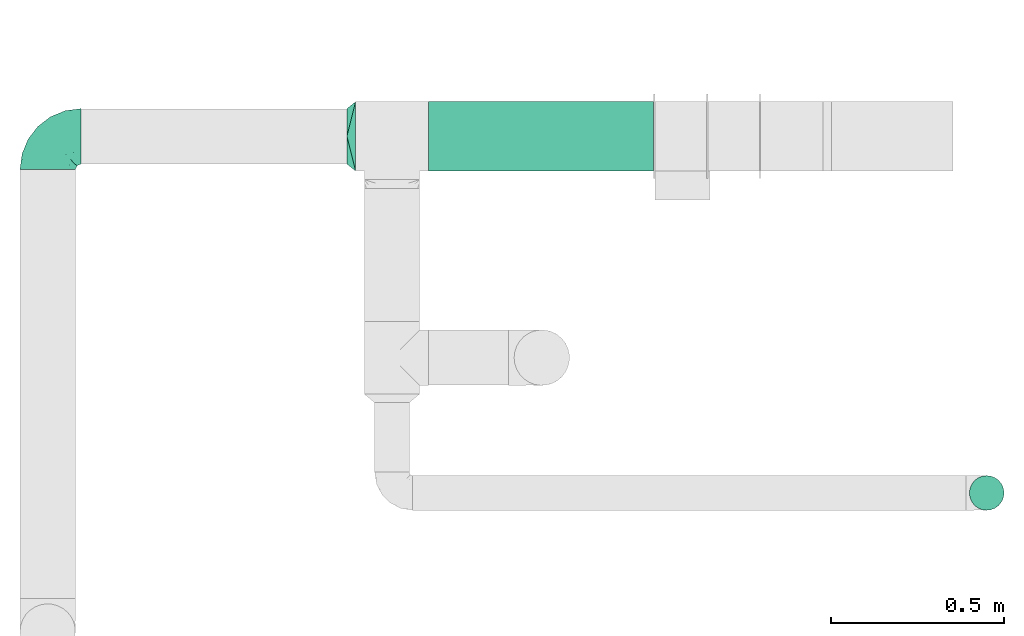
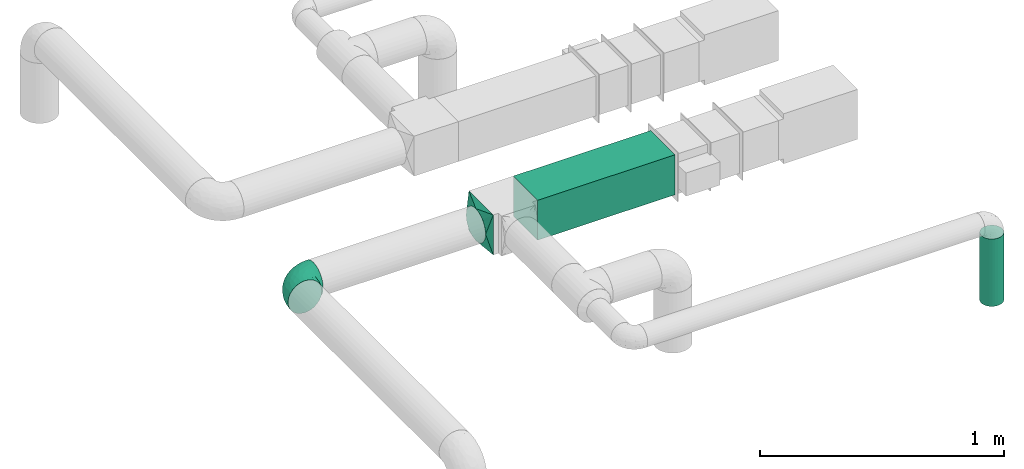
# One storey, part 5 of 12: 2 flow fittings, 2 flow segments.
"""IFC2X3 building model written with IfcOpenShell, lengths in millimetres."""

from ifc_helpers import new_model, entity, si_unit, converted_unit, derived_unit, direction, frame, frame_2d, origin, origin_2d_with_axis, place, context, subcontext, project, spatial, rectangle, circle, extrude, faceted_brep, source, transform, mapped, material, type_object, type_shapes, element, save


model = new_model("IFC2X3")

# Units and contexts
model_context = context("Model", 3, precision=0.01, world=origin(), true_north=direction((6.12303176911189e-17, 1.0)))
body_context = subcontext(model_context, "Body", "Model", "MODEL_VIEW")
ifc_project = project(units=[si_unit("LENGTHUNIT", "METRE", prefix="MILLI"), si_unit("AREAUNIT", "SQUARE_METRE"), si_unit("VOLUMEUNIT", "CUBIC_METRE"), converted_unit("PLANEANGLEUNIT", "DEGREE", entity("IfcRatioMeasure", 0.0174532925199433), si_unit("PLANEANGLEUNIT", "RADIAN"), dimensions=[0, 0, 0, 0, 0, 0, 0]), si_unit("MASSUNIT", "GRAM", prefix="KILO"), derived_unit("MASSDENSITYUNIT", [(si_unit("MASSUNIT", "GRAM", prefix="KILO"), 1), (si_unit("LENGTHUNIT", "METRE"), -3)]), si_unit("TIMEUNIT", "SECOND"), si_unit("FREQUENCYUNIT", "HERTZ"), si_unit("THERMODYNAMICTEMPERATUREUNIT", "DEGREE_CELSIUS"), derived_unit("THERMALTRANSMITTANCEUNIT", [(si_unit("MASSUNIT", "GRAM", prefix="KILO"), 1), (si_unit("THERMODYNAMICTEMPERATUREUNIT", "KELVIN"), -1), (si_unit("TIMEUNIT", "SECOND"), -3)]), derived_unit("VOLUMETRICFLOWRATEUNIT", [(si_unit("LENGTHUNIT", "METRE"), 3), (si_unit("TIMEUNIT", "SECOND"), -1)]), si_unit("ELECTRICCURRENTUNIT", "AMPERE"), si_unit("ELECTRICVOLTAGEUNIT", "VOLT"), si_unit("POWERUNIT", "WATT"), si_unit("FORCEUNIT", "NEWTON", prefix="KILO"), si_unit("ILLUMINANCEUNIT", "LUX"), si_unit("LUMINOUSFLUXUNIT", "LUMEN"), si_unit("LUMINOUSINTENSITYUNIT", "CANDELA"), derived_unit("USERDEFINED", [(si_unit("MASSUNIT", "GRAM", prefix="KILO"), -1), (si_unit("LENGTHUNIT", "METRE"), -2), (si_unit("TIMEUNIT", "SECOND"), 3), (si_unit("LUMINOUSFLUXUNIT", "LUMEN"), 1)]), derived_unit("LINEARVELOCITYUNIT", [(si_unit("LENGTHUNIT", "METRE"), 1), (si_unit("TIMEUNIT", "SECOND"), -1)]), si_unit("PRESSUREUNIT", "PASCAL"), derived_unit("USERDEFINED", [(si_unit("LENGTHUNIT", "METRE"), -2), (si_unit("MASSUNIT", "GRAM", prefix="KILO"), 1), (si_unit("TIMEUNIT", "SECOND"), -2)])], contexts=[model_context])

# Site, building, storey
site_placement = place(None, origin())
site = spatial("IfcSite", under=ifc_project, at=site_placement, CompositionType="ELEMENT")
building_placement = place(site_placement, origin())
building = spatial("IfcBuilding", under=site, at=building_placement, CompositionType="ELEMENT")
storey_placement = place(building_placement, frame((0.0, 0.0, 8000.0)))
storey = spatial("IfcBuildingStorey", under=building, at=storey_placement, Name="02 Level", CompositionType="ELEMENT", Elevation=8000.0)

# Flow segments
duct_segment_type_1 = type_object("IfcDuctSegmentType", Name="Round Duct:Air", PredefinedType="NOTDEFINED")
flow_segment_1_placement = place(storey_placement, frame((24851.8947986159, -70237.5308847274, 2603.07847999992)))
element("IfcFlowSegment", 1, at=flow_segment_1_placement, inside=storey, type_object=duct_segment_type_1, Name="Round Duct:Air", ObjectType="Round Duct:Air", context=body_context, shape_type="SweptSolid", body=[
    extrude(circle(Radius=50.0, at=origin_2d_with_axis()), frame((51.5952722359175, 51.5952722364156, 0.0), z_axis=(0.0, 0.0, 1.0), x_axis=(0.0, 1.0, 0.0)), (0.0, 0.0, 1.0), 336.921519999948),
])
duct_segment_type_2 = type_object("IfcDuctSegmentType", Name="Rectangular Duct:Air", PredefinedType="NOTDEFINED")
flow_segment_2_placement = place(storey_placement, frame((23290.9900708518, -69256.0352293172, 2900.0)))
element("IfcFlowSegment", 2, at=flow_segment_2_placement, inside=storey, type_object=duct_segment_type_2, Name="Rectangular Duct:Air", ObjectType="Rectangular Duct:Air", context=body_context, shape_type="SweptSolid", body=[
    extrude(rectangle(XDim=650.000000000004, YDim=199.999999999998, at=frame_2d((-2.1600499167107e-12, -4.33431068813661e-12), x_axis=(1.0, 0.0))), frame((325.0, 100.0, 0.0), z_axis=(0.0, 0.0, 1.0), x_axis=(-1.0, 0.0, 0.0)), (0.0, 0.0, 1.0), 200.000000000002),
])

# Flow fittings
duct_fitting_type_1 = type_object("IfcDuctFittingType", Name="Air_Elbow short_Circ", PredefinedType="NOTDEFINED")
shared_shape_1 = source(origin(), body_context, "Body", "Brep", [
    faceted_brep([(-96.0, 40.0, -69.2820323027551), (-96.0, 20.7055236082018, -77.2740661031254), (-96.0, 0.0, -80.0), (-96.0, -20.7055236082015, -77.2740661031255), (-96.0, -40.0, -69.2820323027552), (-96.0, -56.5685424949237, -56.5685424949239), (-96.0, -69.282032302755, -40.0), (-96.0, -77.2740661031254, -20.7055236082019), (-96.0, -80.0, 0.0), (-96.0, -77.2740661031256, 20.7055236082014), (-96.0, -69.2820323027553, 40.0), (-96.0, -56.568542494924, 56.5685424949236), (-96.0, -40.0, 69.2820323027549), (-96.0, -20.705523608202, 77.2740661031254), (-96.0, 0.0, 80.0), (-96.0, 20.7055236082013, 77.2740661031256), (-96.0, 30.3527618041005, 73.2780492029404), (-96.0, 40.0, 69.2820323027553), (-96.0, 56.5685424949235, 56.5685424949241), (-96.0, 69.2820323027549, 40.0), (-96.0, 77.2740661031253, 20.7055236082021), (-96.0, 80.0, 0.0), (-96.0, 77.2740661031255, -20.7055236082016), (-96.0, 69.2820323027551, -40.0), (-96.0, 56.5685424949239, -56.5685424949238), (0.0, 96.0, -80.0), (-20.7055236082008, 96.0, -77.2740661031254), (-30.3527618041, 96.0, -73.2780492029402), (-40.0, 96.0, -69.2820323027551), (-56.5685424949229, 96.0, -56.5685424949238), (-69.2820323027542, 96.0, -40.0), (-77.2740661031245, 96.0, -20.7055236082016), (-80.0, 96.0, 0.0), (-77.2740661031244, 96.0, 20.7055236082021), (-69.2820323027539, 96.0, 40.0), (-56.5685424949226, 96.0, 56.5685424949241), (-40.0, 96.0, 69.2820323027553), (-20.7055236082004, 96.0, 77.2740661031256), (0.0, 96.0, 80.0), (20.7055236082029, 96.0, 77.2740661031254), (40.0, 96.0, 69.2820323027549), (56.5685424949249, 96.0, 56.5685424949236), (69.2820323027562, 96.0, 40.0), (77.2740661031265, 96.0, 20.7055236082014), (80.0, 96.0, 0.0), (77.2740661031264, 96.0, -20.7055236082019), (69.2820323027559, 96.0, -40.0), (56.5685424949246, 96.0, -56.5685424949239), (40.0, 96.0, -69.2820323027552), (20.7055236082025, 96.0, -77.2740661031255), (-69.6571465232348, 6.28172173912476, 79.9611058756859), (-55.1380888291464, -64.4450584799279, 39.5029426177976), (-78.4902527850466, -65.2482264041437, 44.9229732355936), (-66.7862289407348, -74.1387210661139, 22.9795507758541), (-79.9123689128389, 22.4151301859584, 77.2816866630488), (-75.1250134759213, 46.3506195730757, 68.0011973810265), (-46.2820694578435, -43.7397705581167, 60.5188244193914), (-62.9760666105318, -34.5362195419601, 70.0448030595901), (-67.1316735243184, -51.7530432423058, 58.5204707533666), (-50.4478480619551, -74.0029454268759, 0.0), (-76.2276812833835, -77.3969248578635, 0.0), (-27.189372084162, 68.980536479128, 76.8941402015288), (-6.30632028234235, 70.6421404093778, 79.9513108199466), (-47.7584488981354, -13.6212410427434, 76.3881123659885), (-29.8609237116382, -28.9682345099716, 65.8760199345924), (57.6005967886466, 33.4719572927763, 39.0176496769077), (51.7530435574228, 67.1316742002235, 58.5204705859065), (43.7397637815864, 46.2820598522933, 60.518827155348), (-74.2591571701267, -14.3645886695287, 78.2829835259588), (28.4507934888335, -28.4507934888321, 0.0), (23.3846344985257, -27.9066135199674, 24.7887114209846), (7.8513563843086, -42.4938374080907, 21.3232874317503), (-84.190871651952, 70.905997349447, 41.7100461919055), (24.7272484782103, -2.06889411058577, 53.4325037134459), (-0.0180155578363953, -25.9284255475521, 53.836744023285), (10.21505333872, -32.0754161621096, 38.020212353501), (-64.5619855594544, 27.52018553659, 77.2892967298799), (-41.7574890626937, 15.123136403511, 79.988056483004), (-24.5336756868846, -60.9669573051438, 23.5003835585885), (-29.2239240309769, -65.2117082464685, 0.0), (-8.0, -56.420471066061, 0.0), (-16.4008295437786, 51.3122057461681, 79.8609584412684), (-83.0529092063249, 83.0529092103045, 19.0855009657076), (-84.6862915010143, 84.6862915010152, 0.0), (-82.4185651555764, 62.2587017800419, 53.3339952483838), (-46.3022193149449, 75.902750025661, 67.8445262622594), (-9.5260688639158, -47.7232209131232, 35.4187162694583), (74.1387213421635, 66.7862279048973, 22.9795492840646), (14.3645870599314, 74.259154996167, 78.2829837700474), (34.536215572589, 62.976064096567, 70.0448048426748), (65.2482273833467, 78.4902510979302, 44.9229715327465), (-12.3935655196116, 25.4017250572252, 78.8652642576962), (-25.6317751341749, 1.2640655514879, 76.9124052095498), (69.8186739706361, 42.5625104806759, 16.7980672722629), (64.4450597015273, 55.1380839274934, 39.5029384026545), (60.9669574479924, 24.5336725945725, 23.5003789659965), (77.3969247188647, 76.2276802275763, 0.0), (74.002945426877, 50.4478480619565, 0.0), (-66.5995156060253, 66.5995146556305, 58.6370817132137), (-52.4774893100348, 53.0631556360015, 72.0041598972686), (-76.4857465466113, 78.9385356944492, 38.5867538667356), (-62.2587016209511, 82.4185645906685, 53.3339956492136), (28.9682276847195, 29.8609133580269, 65.8760207540895), (13.6212369177471, 47.7584433090926, 76.3881128402526), (-6.49930484510329, -53.7890406240985, 15.4645725223014), (-33.731289034344, 40.0214486160993, 79.0537019298314), (46.1336936566893, 26.2441492635858, 50.151541479116), (42.4356322774479, -10.225396744416, 0.0), (56.4204710660622, 8.0, 0.0), (50.0005984633279, 1.26038287501495, 17.5763945268078), (-45.4536887619888, -68.8356359385787, 23.6914879663761), (-33.3493864711472, -57.4572215948989, 39.1720709545353), (35.9683398342664, -11.0724559744972, 30.5391080332169), (-26.2441652621668, -46.1336984778153, 50.1515448602929), (36.6749123583047, -17.5982116941791, 14.5644188861001), (65.2117082464696, 29.2239240309784, 0.0), (49.5968730216335, 12.1440064858134, 34.8325942562253), (-47.1533280807863, 29.0746114834461, 78.9127210009486), (-0.981722938535007, 51.3162880079176, 79.4920802366619), (12.4951682569875, 20.0804783439543, 71.2292489374933), (-1.95170750213435, 1.95169859379814, 70.9272590604952), (13.0725391330592, 1.13338064801589, 63.5790506070627), (-1.93327092594732, -13.4823821925323, 63.7412032706882), (-18.9298205951927, -13.0048872663631, 70.6672094580024), (10.2253967444173, -42.4356322774466, 0.0), (-68.9805369123341, 27.1893702897943, -76.8941406355589), (-22.4151342180024, 79.9123577737124, -77.2816862456941), (-27.5201921618733, 64.5619784506715, -77.2892959136582), (-46.3506180288022, 75.1250185023919, -68.0011970559212), (-74.2591561090454, -14.364589592643, -78.2829832920378), (-42.5625109127564, -69.8186736490614, -16.7980693145318), (-66.78622820047, -74.1387209331735, -22.9795507950237), (-70.6421421271429, 6.30631801763141, -79.9513108797024), (-25.401718902627, 12.3935649209934, -78.8652635038296), (-15.1231475192353, 41.7574898106582, -79.9880566497423), (-1.2640784754681, 25.6317655571971, -76.9124065444174), (-78.9385361639639, 76.4857467527193, -38.5867530236755), (-66.5995166501766, 66.5995137008527, -58.6370816545605), (-82.4185656924104, 62.258701559575, -53.3339952529289), (60.9669567069012, 24.5336743104721, -23.5003834743896), (53.7890400497189, 6.49930371043273, -15.4645720709197), (-55.1380878256228, -64.4450583029017, -39.5029424837467), (-24.5336751436549, -60.9669572920351, -23.5003828649414), (-29.8609212227281, -28.9682353164184, -65.8760186412515), (-26.2441631797834, -46.1336980827234, -50.1515441608816), (-46.2820677406335, -43.7397707662098, -60.5188237522514), (74.1387206827049, 66.7862275406284, -22.9795512458422), (-40.0214489824224, 33.7312845774564, -79.0537024061946), (-78.4902524468744, -65.2482264004152, -44.9229731872606), (-75.902751427461, 46.3022186029078, -67.8445263463497), (-70.9059970555813, 84.1908706304995, -41.7100473389448), (-67.1316724627346, -51.7530434014037, -58.5204704180807), (-62.9760652707231, -34.536220162299, -70.044802546446), (-33.4719630839568, -57.6005950429912, -39.0176564793206), (-51.3122062597491, 16.4008248291117, -79.8609586691244), (-6.28171714934502, 69.65712797409, -79.9611061760713), (51.7530427306645, 67.1316703492073, -58.5204706539109), (-83.0529092397056, 83.0529091932979, -19.0855009185769), (68.8356349913375, 45.45368838847, -23.6914905340598), (-62.258701383479, 82.4185638376438, -53.3339962098694), (34.53621889603, 62.9760621802168, -70.0448028055675), (-1.26038544288408, -50.0005998980998, -17.5763953891677), (13.6212385978137, 47.75844096294, -76.3881120677864), (14.3645887716112, 74.2591526334116, -78.2829833202131), (65.2482261461557, 78.4902526871683, -44.9229735979605), (2.068884460932, -24.7272580800759, -53.4325021883878), (25.9284207554091, 0.0180077987247146, -53.8367428868672), (32.0754071702863, -10.2150656939878, -38.0202105656364), (47.723215348146, 9.52606271707191, -35.4187195087105), (27.9066094773716, -23.3846413342612, -24.7887058003424), (42.4938359077841, -7.8513587520169, -21.3232866357369), (28.9682309044935, 29.8609168472814, -65.8760199178674), (64.4450577206072, 55.1380878066959, -39.5029434692504), (-53.063150048133, 52.4774843719861, -72.0041634993662), (43.7397687897612, 46.2820667462245, -60.5188250739327), (-47.7584463040963, -13.6212426330217, -76.3881115880261), (57.4572201066452, 33.3493827160302, -39.1720708806551), (11.0724494499294, -35.9683446288498, -30.5391089716619), (46.1336964749623, 26.2441642243134, -50.1515465265606), (17.5982028158329, -36.6749194460897, -14.5644209948051), (-12.1440097531109, -49.5968729214507, -34.8325978072281), (-29.0746218055845, 47.1533256390974, -78.912719851915), (-51.3162911259858, 0.981717610547608, -79.4920798409907), (-20.0804667507281, -12.4951842966219, -71.2292388196267), (-1.95170139871169, 1.95169735730944, -70.9272563527003), (-1.13337124471279, -13.072540998247, -63.5790448193562), (13.4823844636247, 1.93327501577089, -63.7412039856557), (13.0048800657406, 18.9298191902065, -70.6672121474654)], [[[0, 1, 2, 3, 4, 5, 6, 7, 8, 9, 10, 11, 12, 13, 14, 15, 16, 17, 18, 19, 20, 21, 22, 23, 24]], [[25, 26, 27, 28, 29, 30, 31, 32, 33, 34, 35, 36, 37, 38, 39, 40, 41, 42, 43, 44, 45, 46, 47, 48, 49]], [[15, 14, 50]], [[51, 52, 53]], [[54, 55, 17]], [[56, 57, 58]], [[59, 53, 60]], [[37, 61, 62]], [[63, 57, 64]], [[65, 66, 67]], [[52, 11, 10]], [[58, 57, 12]], [[68, 14, 13]], [[69, 70, 71]], [[72, 20, 19]], [[57, 63, 68]], [[73, 74, 75]], [[76, 50, 77]], [[13, 12, 57]], [[17, 55, 18]], [[17, 16, 15, 54]], [[78, 79, 80]], [[81, 62, 61]], [[21, 82, 83]], [[57, 56, 64]], [[21, 20, 82]], [[84, 72, 19]], [[12, 11, 58]], [[19, 18, 84]], [[36, 85, 61]], [[75, 74, 86]], [[53, 9, 60]], [[53, 10, 9]], [[42, 87, 43]], [[66, 41, 40]], [[88, 89, 39]], [[42, 41, 90]], [[40, 39, 89]], [[91, 77, 92]], [[87, 42, 90]], [[93, 94, 95]], [[89, 66, 40]], [[87, 96, 43]], [[36, 35, 85]], [[93, 97, 87]], [[85, 98, 99]], [[33, 100, 34]], [[82, 100, 33]], [[100, 98, 101]], [[102, 89, 103]], [[83, 82, 32]], [[78, 80, 104]], [[36, 61, 37]], [[61, 85, 99]], [[105, 77, 91]], [[102, 106, 67]], [[35, 34, 101]], [[37, 62, 38]], [[107, 108, 109]], [[110, 51, 53]], [[88, 39, 38]], [[78, 110, 79]], [[59, 79, 110]], [[51, 110, 111]], [[75, 70, 112]], [[111, 86, 113]], [[107, 114, 69]], [[106, 102, 73]], [[115, 93, 95]], [[62, 88, 38]], [[115, 95, 108]], [[116, 95, 65]], [[95, 116, 109]], [[68, 50, 14]], [[76, 77, 117]], [[76, 117, 99]], [[84, 55, 98]], [[101, 85, 35]], [[98, 55, 99]], [[81, 61, 105]], [[62, 118, 88]], [[67, 66, 89]], [[90, 66, 94]], [[52, 58, 11]], [[58, 51, 111]], [[50, 63, 77]], [[92, 77, 63]], [[119, 91, 120]], [[81, 118, 62]], [[120, 121, 119]], [[73, 112, 116]], [[120, 122, 121]], [[123, 122, 120]], [[74, 64, 113]], [[92, 123, 120]], [[74, 113, 86]], [[73, 121, 122]], [[76, 99, 55]], [[61, 99, 105]], [[9, 8, 60]], [[96, 87, 97]], [[96, 44, 43]], [[89, 88, 103]], [[57, 68, 13]], [[50, 68, 63]], [[100, 101, 34]], [[85, 101, 98]], [[55, 84, 18]], [[72, 98, 100]], [[105, 91, 81]], [[118, 91, 103]], [[91, 118, 81]], [[88, 118, 103]], [[98, 72, 84]], [[72, 100, 82]], [[82, 20, 72]], [[32, 82, 33]], [[53, 52, 10]], [[58, 52, 51]], [[66, 90, 41]], [[87, 90, 94]], [[76, 55, 54]], [[15, 50, 54]], [[50, 76, 54]], [[110, 53, 59]], [[111, 110, 78]], [[78, 104, 86]], [[111, 113, 56]], [[78, 86, 111]], [[86, 71, 75]], [[70, 75, 71]], [[73, 75, 112]], [[104, 124, 71]], [[95, 109, 108]], [[70, 114, 112]], [[94, 65, 95]], [[114, 109, 112]], [[69, 114, 70]], [[109, 114, 107]], [[73, 116, 106]], [[112, 109, 116]], [[66, 65, 94]], [[106, 116, 65]], [[97, 93, 115]], [[86, 104, 71]], [[124, 104, 80]], [[124, 69, 71]], [[94, 93, 87]], [[102, 67, 89]], [[65, 67, 106]], [[111, 56, 58]], [[64, 56, 113]], [[77, 105, 117]], [[99, 117, 105]], [[123, 63, 64]], [[91, 92, 120]], [[63, 123, 92]], [[122, 64, 74]], [[64, 122, 123]], [[73, 122, 74]], [[73, 102, 121]], [[119, 121, 102]], [[102, 103, 119]], [[91, 119, 103]], [[0, 125, 1]], [[126, 127, 128]], [[3, 2, 129]], [[130, 59, 131]], [[1, 132, 2]], [[133, 134, 135]], [[136, 137, 138]], [[139, 108, 140]], [[23, 138, 24]], [[130, 141, 142]], [[23, 22, 136]], [[143, 144, 145]], [[146, 46, 45]], [[147, 134, 133]], [[131, 6, 148]], [[0, 24, 149]], [[131, 60, 7]], [[150, 31, 30]], [[151, 4, 152]], [[153, 151, 145]], [[5, 4, 151]], [[4, 3, 152]], [[154, 132, 125]], [[5, 148, 6]], [[26, 25, 155]], [[3, 129, 152]], [[6, 131, 7]], [[48, 47, 156]], [[21, 83, 157]], [[139, 158, 115]], [[32, 31, 157]], [[157, 136, 22]], [[30, 159, 150]], [[49, 48, 160]], [[124, 80, 161]], [[29, 159, 30]], [[28, 27, 26, 126]], [[149, 125, 0]], [[127, 155, 134]], [[160, 162, 163]], [[164, 47, 46]], [[29, 28, 128]], [[165, 166, 167]], [[49, 163, 25]], [[168, 167, 166]], [[1, 125, 132]], [[139, 115, 108]], [[69, 169, 170]], [[162, 160, 171]], [[156, 160, 48]], [[172, 164, 146]], [[149, 137, 173]], [[146, 96, 97]], [[160, 174, 171]], [[143, 152, 175]], [[156, 174, 160]], [[125, 149, 173]], [[126, 128, 28]], [[97, 115, 158]], [[157, 22, 21]], [[158, 172, 146]], [[146, 45, 96]], [[172, 158, 176]], [[167, 169, 177]], [[176, 168, 178]], [[124, 179, 69]], [[144, 143, 165]], [[79, 130, 142]], [[45, 44, 96]], [[79, 142, 80]], [[180, 142, 153]], [[142, 180, 161]], [[163, 155, 25]], [[181, 134, 147]], [[127, 181, 173]], [[159, 128, 137]], [[138, 149, 24]], [[137, 128, 173]], [[154, 125, 147]], [[132, 182, 129]], [[145, 151, 152]], [[148, 151, 141]], [[164, 156, 47]], [[156, 172, 176]], [[155, 162, 134]], [[135, 134, 162]], [[183, 133, 184]], [[154, 182, 132]], [[184, 185, 183]], [[165, 177, 180]], [[184, 186, 185]], [[187, 186, 184]], [[166, 171, 178]], [[135, 187, 184]], [[166, 178, 168]], [[165, 185, 186]], [[127, 173, 128]], [[125, 173, 147]], [[60, 131, 59]], [[60, 8, 7]], [[132, 129, 2]], [[152, 129, 175]], [[160, 163, 49]], [[155, 163, 162]], [[136, 138, 23]], [[149, 138, 137]], [[128, 159, 29]], [[150, 137, 136]], [[147, 133, 154]], [[182, 133, 175]], [[133, 182, 154]], [[129, 182, 175]], [[137, 150, 159]], [[150, 136, 157]], [[32, 157, 83]], [[157, 31, 150]], [[146, 164, 46]], [[156, 164, 172]], [[151, 148, 5]], [[131, 148, 141]], [[127, 126, 155]], [[26, 155, 126]], [[158, 146, 97]], [[176, 158, 139]], [[139, 140, 168]], [[176, 178, 174]], [[139, 168, 176]], [[168, 170, 167]], [[169, 167, 170]], [[165, 167, 177]], [[140, 107, 170]], [[142, 161, 80]], [[169, 179, 177]], [[141, 153, 142]], [[179, 161, 177]], [[69, 179, 169]], [[161, 179, 124]], [[165, 180, 144]], [[177, 161, 180]], [[151, 153, 141]], [[144, 180, 153]], [[59, 130, 79]], [[168, 140, 170]], [[107, 140, 108]], [[107, 69, 170]], [[141, 130, 131]], [[143, 145, 152]], [[153, 145, 144]], [[176, 174, 156]], [[171, 174, 178]], [[173, 181, 147]], [[127, 134, 181]], [[187, 162, 171]], [[133, 135, 184]], [[162, 187, 135]], [[186, 171, 166]], [[171, 186, 187]], [[165, 186, 166]], [[165, 143, 185]], [[183, 185, 143]], [[143, 175, 183]], [[133, 183, 175]]]),
])
type_shapes(duct_fitting_type_1, [shared_shape_1])
flow_fitting_1_placement = place(storey_placement, frame((22191.748982204, -69156.0352293172, 3000.0), z_axis=(0.0, 0.0, 1.0), x_axis=(-1.0, 0.0, 0.0)))
element("IfcFlowFitting", 3, at=flow_fitting_1_placement, inside=storey, type_object=duct_fitting_type_1, Name="elbow_short_001:Air_Elbow short_Circ", ObjectType="elbow_short_001:Air_Elbow short_Circ", context=body_context, shape_type="MappedRepresentation", body=[
    mapped(shared_shape_1, transform((0.0, 0.0, 0.0), scale=1.0)),
])
ifc_material = material(Name="Material_Duct")
duct_fitting_type_2 = type_object("IfcDuctFittingType", Name="Air_Multi shape transition_Circ", PredefinedType="NOTDEFINED", material=ifc_material)
shared_shape_2 = source(origin(), body_context, "Body", "Brep", [
    faceted_brep([(25.0, -30.614674589207, -73.9103626009021), (25.0, -22.8665162204521, -75.4515671248636), (25.0, -15.1183578516973, -76.9927716488251), (25.0, -11.3387683887729, -77.7445787366186), (25.0, -7.55917892584856, -78.4963858244121), (25.0, 0.0, -80.0), (25.0, 7.55917891579331, -78.4963858264122), (25.0, 15.1183578315867, -76.9927716528254), (25.0, 18.9924370209918, -76.2221693898445), (25.0, 22.8665162103969, -75.4515671268637), (25.0, 30.6146745892071, -73.9103626009021), (25.0, 37.1031415656363, -69.5749075744073), (25.0, 43.5916085420654, -65.2394525479125), (25.0, 50.0800755184946, -60.9039975214177), (25.0, 56.5685424949238, -56.5685424949229), (25.0, 60.9039975214186, -50.0800755184938), (25.0, 65.2394525479134, -43.5916085420646), (25.0, 69.5749075744082, -37.1031415656355), (25.0, 73.910362600903, -30.6146745892063), (25.0, 75.4515671248645, -22.8665162204514), (25.0, 76.992771648826, -15.1183578516966), (25.0, 77.7445787366195, -11.3387683887722), (25.0, 78.496385824413, -7.55917892584782), (25.0, 80.0, 0.0), (25.0, 78.4963858264131, 7.55917891579322), (25.0, 76.9927716528263, 15.1183578315867), (25.0, 76.2221693898455, 18.9924370209917), (25.0, 75.4515671268647, 22.8665162103968), (25.0, 73.910362600903, 30.614674589207), (25.0, 69.5749075744082, 37.1031415656362), (25.0, 65.2394525479135, 43.5916085420653), (25.0, 60.9039975214187, 50.0800755184945), (25.0, 56.5685424949239, 56.5685424949237), (25.0, 50.0800755184948, 60.9039975214185), (25.0, 43.5916085420656, 65.2394525479133), (25.0, 37.1031415656365, 69.5749075744081), (25.0, 30.6146745892073, 73.9103626009029), (25.0, 22.8665162204525, 75.4515671248644), (25.0, 15.1183578516976, 76.992771648826), (25.0, 11.3387683887732, 77.7445787366195), (25.0, 7.55917892584888, 78.496385824413), (25.0, 0.0, 80.0), (25.0, -7.55917891579326, 78.4963858264132), (25.0, -15.1183578315867, 76.9927716528263), (25.0, -18.9924370209918, 76.2221693898455), (25.0, -22.8665162103969, 75.4515671268647), (25.0, -30.6146745892071, 73.910362600903), (25.0, -37.1031415656362, 69.5749075744082), (25.0, -43.5916085420654, 65.2394525479134), (25.0, -50.0800755184946, 60.9039975214187), (25.0, -56.5685424949237, 56.5685424949239), (25.0, -60.9039975214185, 50.0800755184947), (25.0, -65.2394525479133, 43.5916085420656), (25.0, -69.5749075744081, 37.1031415656364), (25.0, -73.9103626009029, 30.6146745892072), (25.0, -75.4515671248645, 22.8665162204524), (25.0, -76.992771648826, 15.1183578516975), (25.0, -77.7445787366195, 11.3387683887731), (25.0, -78.496385824413, 7.55917892584876), (25.0, -80.0, 0.0), (25.0, -78.4963858264131, -7.55917891579276), (25.0, -76.9927716528262, -15.1183578315862), (25.0, -76.2221693898453, -18.9924370209913), (25.0, -75.4515671268645, -22.8665162103963), (25.0, -73.9103626009028, -30.6146745892065), (25.0, -69.574907574408, -37.1031415656356), (25.0, -65.2394525479132, -43.5916085420648), (25.0, -60.9039975214184, -50.0800755184939), (25.0, -56.5685424949236, -56.5685424949231), (25.0, -50.0800755184945, -60.9039975214178), (25.0, -43.5916085420653, -65.2394525479126), (25.0, -37.1031415656362, -69.5749075744073), (0.0, -100.0, 100.0), (0.0, 100.0, 100.0), (0.0, 100.0, -100.0), (0.0, -100.0, -100.0), (6.50713916945186, -73.9714433221932, 94.7942886644397), (9.76070875417778, -60.9571649832894, 92.1914329966587), (22.0035695847259, -11.9857216610963, 82.3971443322195), (19.0071391694519, -23.9714433221927, 84.7942886644389), (16.0107087541778, -35.9571649832891, 87.1914329966584), (13.0142783389037, -47.9428866443855, 89.5885773288778), (12.5000000004112, -79.9443399349057, 76.5204921859004), (9.76070845754317, -92.191433233966, 60.9571661698283), (13.0142779433909, -89.5885776452877, 47.9428882264372), (16.0107084575432, -87.1914332339658, 35.9571661698279), (19.0071389716954, -84.7942888226439, 23.9714441132186), (20.5053542287716, -83.5957166169829, 17.978583084914), (22.0035694858477, -82.3971444113219, 11.9857220566093), (3.25356948584772, -97.3971444113226, 86.9857220566105), (6.50713897169545, -94.7942888226443, 73.9714441132194), (3.25356958472593, -86.9857216610971, 97.3971443322206), (3.25356958472592, -97.39714433222, -86.9857216610962), (6.50713916945185, -94.7942886644392, -73.9714433221924), (9.76070875417777, -92.1914329966583, -60.9571649832887), (13.0142783389037, -89.5885773288775, -47.9428866443849), (16.0107087541778, -87.1914329966581, -35.9571649832885), (19.0071391694518, -84.7942886644387, -23.9714433221921), (22.0035695847259, -82.3971443322194, -11.9857216610957), (12.5000000004112, -76.5204921859, -79.9443399349049), (9.76070845754315, -60.9571661698279, -92.1914332339651), (13.0142779433909, -47.9428882264369, -89.5885776452868), (16.0107084575432, -35.9571661698276, -87.1914332339649), (19.0071389716954, -23.9714441132183, -84.794288822643), (20.5053542287716, -17.9785830849137, -83.595716616982), (22.0035694858477, -11.9857220566091, -82.397144411321), (3.25356948584772, -86.9857220566099, -97.3971444113217), (6.50713897169543, -73.9714441132189, -94.7942888226434), (3.25356958472593, 86.9857216610957, -97.3971443322191), (6.50713916945185, 73.9714433221921, -94.7942886644383), (9.76070875417778, 60.9571649832884, -92.1914329966574), (13.0142783389037, 47.9428866443848, -89.5885773288765), (16.0107087541778, 35.9571649832886, -87.1914329966572), (19.0071391694519, 23.9714433221924, -84.7942886644378), (22.0035695847259, 11.9857216610961, -82.3971443322185), (12.5000000004112, 79.944339934905, -76.5204921858991), (9.76070845754316, 92.1914332339651, -60.957166169827), (13.0142779433909, 89.588577645287, -47.942888226436), (16.0107084575432, 87.1914332339653, -35.9571661698268), (19.0071389716954, 84.7942888226435, -23.9714441132175), (20.5053542287716, 83.5957166169826, -17.9785830849129), (22.0035694858477, 82.3971444113217, -11.9857220566083), (3.25356948584772, 97.3971444113213, -86.985722056609), (6.50713897169544, 94.7942888226432, -73.971444113218), (3.25356958472593, 97.3971443322187, 86.9857216610977), (6.50713916945185, 94.7942886644381, 73.9714433221937), (9.76070875417778, 92.1914329966574, 60.9571649832898), (13.0142783389037, 89.5885773288767, 47.9428866443859), (16.0107087541778, 87.1914329966576, 35.9571649832893), (19.0071391694519, 84.7942886644384, 23.9714433221928), (22.0035695847259, 82.3971443322192, 11.9857216610963), (12.5000000004112, 76.5204921858994, 79.9443399349061), (9.76070845754316, 60.957166169827, 92.1914332339665), (13.0142779433909, 47.9428882264362, 89.5885776452881), (16.0107084575432, 35.9571661698272, 87.191433233966), (19.0071389716954, 23.9714441132182, 84.794288822644), (20.5053542287716, 17.9785830849137, 83.595716616983), (22.0035694858477, 11.9857220566092, 82.397144411322), (3.25356948584772, 86.9857220566086, 97.3971444113232), (6.50713897169544, 73.9714441132178, 94.7942888226448)], [[[0, 1, 2, 3, 4, 5, 6, 7, 8, 9, 10, 11, 12, 13, 14, 15, 16, 17, 18, 19, 20, 21, 22, 23, 24, 25, 26, 27, 28, 29, 30, 31, 32, 33, 34, 35, 36, 37, 38, 39, 40, 41, 42, 43, 44, 45, 46, 47, 48, 49, 50, 51, 52, 53, 54, 55, 56, 57, 58, 59, 60, 61, 62, 63, 64, 65, 66, 67, 68, 69, 70, 71]], [[72, 73, 74, 75]], [[76, 48, 77]], [[48, 47, 46, 77]], [[78, 79, 80, 81, 77, 46, 45, 44, 43, 42, 41]], [[49, 82, 50]], [[56, 55, 54, 83, 84, 85, 86, 87, 88, 59, 58, 57]], [[82, 72, 89]], [[82, 51, 50]], [[83, 52, 90]], [[91, 72, 82]], [[54, 53, 52, 83]], [[90, 52, 51]], [[51, 82, 89]], [[90, 51, 89]], [[76, 49, 48]], [[49, 76, 91]], [[82, 49, 91]], [[88, 87, 86, 85, 84, 83, 90, 89, 72, 75, 92, 93, 94, 95, 96, 97, 98, 59]], [[93, 66, 94]], [[66, 65, 64, 94]], [[98, 97, 96, 95, 94, 64, 63, 62, 61, 60, 59]], [[67, 99, 68]], [[2, 1, 0, 100, 101, 102, 103, 104, 105, 5, 4, 3]], [[99, 75, 106]], [[99, 69, 68]], [[100, 70, 107]], [[92, 75, 99]], [[0, 71, 70, 100]], [[107, 70, 69]], [[69, 99, 106]], [[107, 69, 106]], [[93, 67, 66]], [[67, 93, 92]], [[99, 67, 92]], [[105, 104, 103, 102, 101, 100, 107, 106, 75, 74, 108, 109, 110, 111, 112, 113, 114, 5]], [[109, 12, 110]], [[12, 11, 10, 110]], [[114, 113, 112, 111, 110, 10, 9, 8, 7, 6, 5]], [[13, 115, 14]], [[20, 19, 18, 116, 117, 118, 119, 120, 121, 23, 22, 21]], [[115, 74, 122]], [[115, 15, 14]], [[116, 16, 123]], [[108, 74, 115]], [[18, 17, 16, 116]], [[123, 16, 15]], [[15, 115, 122]], [[123, 15, 122]], [[109, 13, 12]], [[13, 109, 108]], [[115, 13, 108]], [[74, 73, 124, 125, 126, 127, 128, 129, 130, 23, 121, 120, 119, 118, 117, 116, 123, 122]], [[125, 30, 126]], [[30, 29, 28, 126]], [[130, 129, 128, 127, 126, 28, 27, 26, 25, 24, 23]], [[31, 131, 32]], [[38, 37, 36, 132, 133, 134, 135, 136, 137, 41, 40, 39]], [[131, 73, 138]], [[131, 33, 32]], [[132, 34, 139]], [[124, 73, 131]], [[36, 35, 34, 132]], [[139, 34, 33]], [[33, 131, 138]], [[139, 33, 138]], [[125, 31, 30]], [[31, 125, 124]], [[131, 31, 124]], [[73, 72, 91, 76, 77, 81, 80, 79, 78, 41, 137, 136, 135, 134, 133, 132, 139, 138]]]),
])
type_shapes(duct_fitting_type_2, [shared_shape_2])
flow_fitting_2_placement = place(storey_placement, frame((23080.9900708518, -69156.0352293172, 3000.0), z_axis=(0.0, 0.0, 1.0), x_axis=(-1.0, 0.0, 0.0)))
element("IfcFlowFitting", 4, at=flow_fitting_2_placement, inside=storey, type_object=duct_fitting_type_2, material=ifc_material, Name="multi_shape_trans_001:Air_Multi shape transition_Circ", ObjectType="multi_shape_trans_001:Air_Multi shape transition_Circ", context=body_context, shape_type="MappedRepresentation", body=[
    mapped(shared_shape_2, transform((0.0, 0.0, 0.0), scale=1.0)),
])

save(model, "model.ifc")
